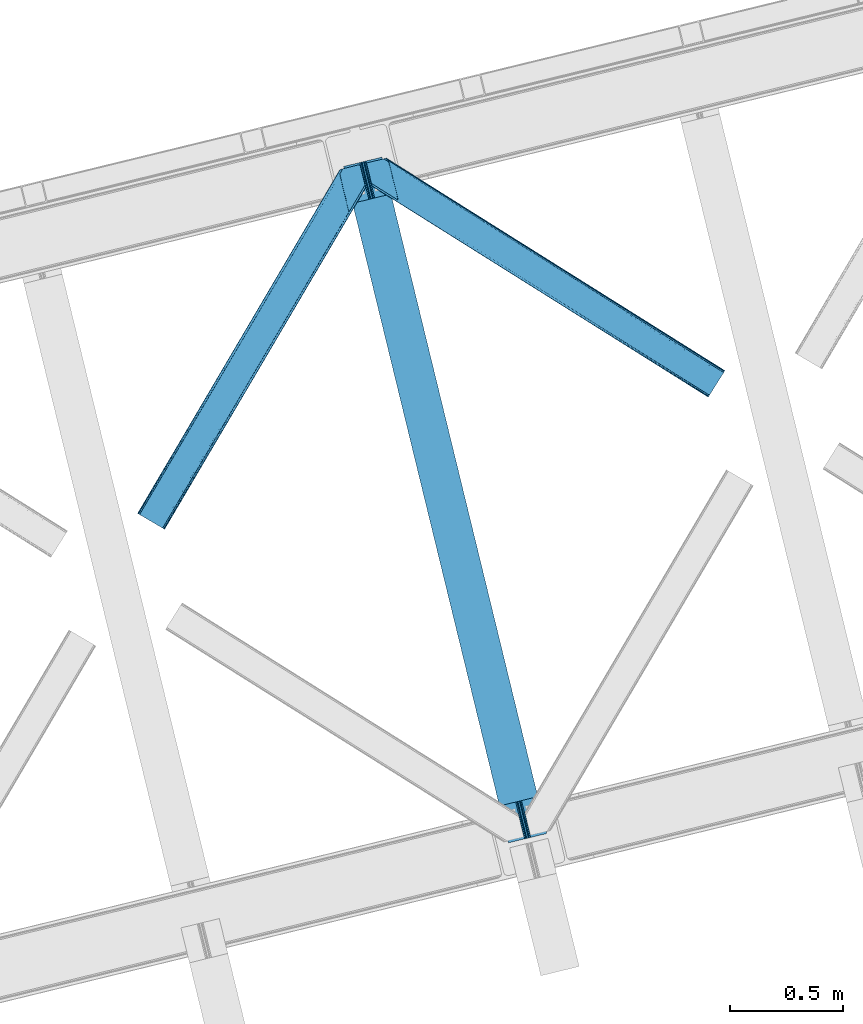
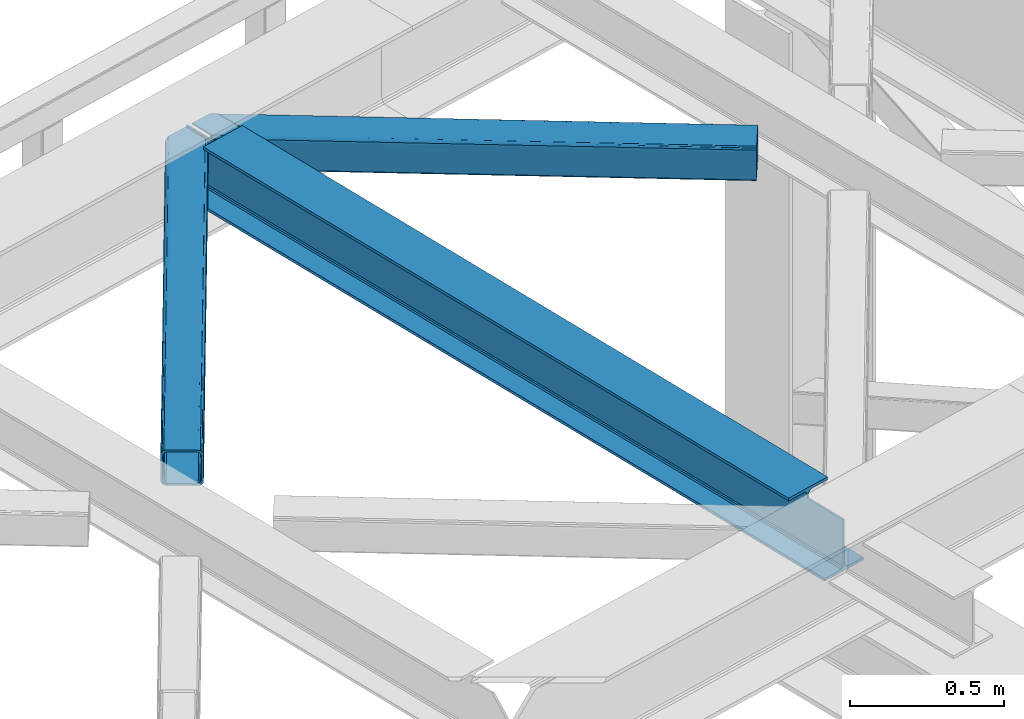
# One storey, part 35 of 93: 2 members, 1 beam.
"""IFC4 building model written with IfcOpenShell, lengths in millimetres."""

import ifcopenshell
import ifcopenshell.guid

model = None  # the IFC model being written
_history = None  # IfcOwnerHistory: only IFC2X3 demands one
_inside = {}  # id of a spatial element -> (the spatial element, [elements in it])
_under = {}  # id of a project, library or spatial element -> (it, [spatial elements below it])
_declared = {}  # id of a project -> (the project, [libraries it declares])
_typed = {}  # id of a type object -> (the type object, [elements of that type])
_made_of = {}  # id of a material, layer set ... -> (it, [elements and type objects made of it])


def new_model(schema):
    """Start an empty IFC model of exactly this schema.

    Asked for "IFC4X3", IfcOpenShell would pick the latest addendum, in which some entities
    have other attributes; the version numbers below select the first issue.
    IFC2X3 requires an IfcOwnerHistory on every rooted entity: one is made here for all.
    """
    global model, _history
    if schema == "IFC4X3":
        model = ifcopenshell.file(schema_version=(4, 3, 0, 0))
    else:
        model = ifcopenshell.file(schema=schema)
    _inside.clear()
    _under.clear()
    _declared.clear()
    _typed.clear()
    _made_of.clear()
    _history = None
    if model.schema == "IFC2X3":
        org = make("IfcOrganization", Name="unknown")
        user = make(
            "IfcPersonAndOrganization",
            ThePerson=make("IfcPerson", FamilyName="unknown"),
            TheOrganization=org,
        )
        app = make(
            "IfcApplication",
            ApplicationDeveloper=org,
            Version="unknown",
            ApplicationFullName="unknown",
            ApplicationIdentifier="unknown",
        )
        _history = make(
            "IfcOwnerHistory",
            OwningUser=user,
            OwningApplication=app,
            ChangeAction="ADDED",
            CreationDate=0,
        )
    return model


def make(cls, **values):
    """One entity of the class cls with the attributes given. An attribute that is None is left unset."""
    return model.create_entity(
        cls, **{name: value for name, value in values.items() if value is not None}
    )


def entity(cls, *values):
    """Any entity or typed value of the class cls, its attributes in the order of the schema. None: left unset."""
    e = model.create_entity(cls)
    for i, value in enumerate(values):
        if value is not None:
            e[i] = value
    return e


def rooted(cls, **values):
    """An entity with a GlobalId (a new one), such as an element, a storey or a relation."""
    return make(cls, GlobalId=ifcopenshell.guid.new(), OwnerHistory=_history, **values)


def si_unit(unit_type, name, prefix=None):
    """IfcSIUnit, for example si_unit("LENGTHUNIT", "METRE", prefix="MILLI")."""
    return make("IfcSIUnit", UnitType=unit_type, Prefix=prefix, Name=name)


def converted_unit(unit_type, name, factor, base, dimensions=None, offset=None):
    """IfcConversionBasedUnit, such as the inch: factor (a typed value) times the base unit."""
    return make(
        "IfcConversionBasedUnit"
        if offset is None
        else "IfcConversionBasedUnitWithOffset",
        ConversionOffset=offset,
        Dimensions=None
        if dimensions is None
        else entity("IfcDimensionalExponents", *dimensions),
        UnitType=unit_type,
        Name=name,
        ConversionFactor=make(
            "IfcMeasureWithUnit", ValueComponent=factor, UnitComponent=base
        ),
    )


def derived_unit(unit_type, elements):
    """IfcDerivedUnit: a product of units, each with its exponent."""
    return make(
        "IfcDerivedUnit",
        Elements=[
            make("IfcDerivedUnitElement", Unit=unit, Exponent=power)
            for unit, power in elements
        ],
        UnitType=unit_type,
    )


def assignment(units):
    """IfcUnitAssignment: the units of a project."""
    return None if units is None else make("IfcUnitAssignment", Units=units)


def point(xyz):
    """IfcCartesianPoint."""
    return None if xyz is None else make("IfcCartesianPoint", Coordinates=xyz)


def direction(xyz):
    """IfcDirection."""
    return None if xyz is None else make("IfcDirection", DirectionRatios=xyz)


def frame(location, z_axis=None, x_axis=None):
    """IfcAxis2Placement3D, a coordinate frame: its origin and axes. An axis left out is left unset."""
    return make(
        "IfcAxis2Placement3D",
        Location=point(location),
        Axis=direction(z_axis),
        RefDirection=direction(x_axis),
    )


def origin():
    """The frame at (0, 0, 0) with its axes left unset."""
    return frame((0.0, 0.0, 0.0))


def place(relative_to, where):
    """IfcLocalPlacement: puts the frame where relative to a parent placement (None: the world)."""
    return make(
        "IfcLocalPlacement", PlacementRelTo=relative_to, RelativePlacement=where
    )


def context(
    kind, dimensions, precision=None, world=None, true_north=None, identifier=None
):
    """IfcGeometricRepresentationContext, for example the 3D "Model" context."""
    return make(
        "IfcGeometricRepresentationContext",
        ContextIdentifier=identifier,
        ContextType=kind,
        CoordinateSpaceDimension=dimensions,
        Precision=precision,
        WorldCoordinateSystem=world,
        TrueNorth=true_north,
    )


def subcontext(parent, identifier, kind, view, scale=None):
    """IfcGeometricRepresentationSubContext, for example "Body" below "Model"."""
    return make(
        "IfcGeometricRepresentationSubContext",
        ContextIdentifier=identifier,
        ContextType=kind,
        ParentContext=parent,
        TargetScale=scale,
        TargetView=view,
    )


def project(units=None, contexts=None):
    """IfcProject with its units and contexts."""
    return rooted(
        "IfcProject",
        Name="project",
        RepresentationContexts=contexts,
        UnitsInContext=assignment(units),
    )


def spatial(cls, under=None, at=None, **own):
    """A site, building, storey or space (cls), placed at a placement, below another one or the project."""
    s = rooted(cls, ObjectPlacement=at, **own)
    if under is not None:
        _under.setdefault(under.id(), (under, []))[1].append(s)
    return s


def point_list(points):
    """IfcCartesianPointList2D or 3D."""
    cls = (
        "IfcCartesianPointList2D" if len(points[0]) == 2 else "IfcCartesianPointList3D"
    )
    return make(cls, CoordList=points)


def triangles(points, corners, closed=None, point_numbers=None):
    """IfcTriangulatedFaceSet: each triangle names its three corners, points numbered from 1."""
    return make(
        "IfcTriangulatedFaceSet",
        Coordinates=point_list(points),
        Closed=closed,
        CoordIndex=corners,
        PnIndex=point_numbers,
    )


def polygons(points, faces, closed=None, point_numbers=None):
    """IfcPolygonalFaceSet: a face is its outer loop, then its inner loops; points numbered from 1."""
    made = []
    for loops in faces:
        if len(loops) == 1:
            made.append(make("IfcIndexedPolygonalFace", CoordIndex=loops[0]))
        else:
            made.append(
                make(
                    "IfcIndexedPolygonalFaceWithVoids",
                    CoordIndex=loops[0],
                    InnerCoordIndices=loops[1:],
                )
            )
    return make(
        "IfcPolygonalFaceSet",
        Coordinates=point_list(points),
        Closed=closed,
        Faces=made,
        PnIndex=point_numbers,
    )


def shape(context_of_items, identifier, shape_type, items):
    """IfcShapeRepresentation: the items that make up one representation, for example the "Body"."""
    return make(
        "IfcShapeRepresentation",
        ContextOfItems=context_of_items,
        RepresentationIdentifier=identifier,
        RepresentationType=shape_type,
        Items=items,
    )


def material(Name=None, Category=None):
    """IfcMaterial."""
    return make("IfcMaterial", Name=Name, Category=Category)


def made_of(thing, what):
    """Note that an element or type object is made of a material, layer set ...; save() writes the relation."""
    if what is not None:
        _made_of.setdefault(what.id(), (what, []))[1].append(thing)
    return thing


def type_object(cls, material=None, **own):
    """A type object (cls), such as IfcWallType, which elements share."""
    return made_of(rooted(cls, **own), material)


def element(
    cls,
    number,
    at=None,
    inside=None,
    cuts=None,
    type_object=None,
    material=None,
    context=None,
    identifier="Body",
    shape_type=None,
    held_by="IfcProductDefinitionShape",
    body=None,
    shapes=None,
    **own,
):
    """One element of the class cls, such as IfcWall. Its Tag is "e" and its number.

    at: its placement. inside: the storey or other place that contains it. cuts: it is an
    opening in that element (IfcRelVoidsElement). A single representation is given by context,
    identifier, shape_type and body (its items); several are given by shapes. held_by: the class
    of the entity that holds the representations. save() writes the other relations.
    """
    e = rooted(cls, Tag="e%d" % number, ObjectPlacement=at, **own)
    if body is not None:
        shapes = [shape(context, identifier, shape_type, body)]
    if shapes is not None:
        e.Representation = make(held_by, Representations=shapes)
    if inside is not None:
        _inside.setdefault(inside.id(), (inside, []))[1].append(e)
    if cuts is not None:
        rooted(
            "IfcRelVoidsElement", RelatingBuildingElement=cuts, RelatedOpeningElement=e
        )
    if type_object is not None:
        _typed.setdefault(type_object.id(), (type_object, []))[1].append(e)
    return made_of(e, material)


def aggregate(whole, parts):
    """IfcRelAggregates: a whole, such as a stair, and the parts it consists of."""
    return rooted("IfcRelAggregates", RelatingObject=whole, RelatedObjects=parts)


def save(model, path):
    """Write the relations noted so far, then the file.

    IfcRelAggregates (storeys below a building ...), IfcRelContainedInSpatialStructure (elements
    in a storey), IfcRelDefinesByType, IfcRelAssociatesMaterial and IfcRelDeclares: one each for
    every whole, place, type object, material and project.
    """
    for whole, parts in _under.values():
        aggregate(whole, parts)
    for where, things in _inside.values():
        rooted(
            "IfcRelContainedInSpatialStructure",
            RelatedElements=things,
            RelatingStructure=where,
        )
    for kind, things in _typed.values():
        rooted("IfcRelDefinesByType", RelatedObjects=things, RelatingType=kind)
    for what, things in _made_of.values():
        rooted("IfcRelAssociatesMaterial", RelatedObjects=things, RelatingMaterial=what)
    for by, libraries in _declared.values():
        rooted("IfcRelDeclares", RelatingContext=by, RelatedDefinitions=libraries)
    model.write(path)


model = new_model("IFC4")

# Units and contexts
model_context = context("Model", 3, precision=0.01, world=origin(), true_north=direction((6.12303176911189e-17, 1.0)))
plan_context = context("Plan", 3, precision=0.01, world=origin(), true_north=direction((6.12303176911189e-17, 1.0)))
body_context = subcontext(model_context, "Body", "Model", "MODEL_VIEW")
ifc_project = project(units=[si_unit("LENGTHUNIT", "METRE", prefix="MILLI"), si_unit("AREAUNIT", "SQUARE_METRE"), si_unit("VOLUMEUNIT", "CUBIC_METRE"), converted_unit("PLANEANGLEUNIT", "DEGREE", entity("IfcRatioMeasure", 0.0174532925199433), si_unit("PLANEANGLEUNIT", "RADIAN"), dimensions=[0, 0, 0, 0, 0, 0, 0]), si_unit("MASSUNIT", "GRAM", prefix="KILO"), derived_unit("MASSDENSITYUNIT", [(si_unit("MASSUNIT", "GRAM", prefix="KILO"), 1), (si_unit("LENGTHUNIT", "METRE"), -3)]), derived_unit("MOMENTOFINERTIAUNIT", [(si_unit("LENGTHUNIT", "METRE"), 4)]), si_unit("TIMEUNIT", "SECOND"), si_unit("FREQUENCYUNIT", "HERTZ"), si_unit("THERMODYNAMICTEMPERATUREUNIT", "DEGREE_CELSIUS"), derived_unit("THERMALTRANSMITTANCEUNIT", [(si_unit("MASSUNIT", "GRAM", prefix="KILO"), 1), (si_unit("THERMODYNAMICTEMPERATUREUNIT", "KELVIN"), -1), (si_unit("TIMEUNIT", "SECOND"), -3)]), derived_unit("VOLUMETRICFLOWRATEUNIT", [(si_unit("LENGTHUNIT", "METRE"), 3), (si_unit("TIMEUNIT", "SECOND"), -1)]), derived_unit("MASSFLOWRATEUNIT", [(si_unit("MASSUNIT", "GRAM", prefix="KILO"), 1), (si_unit("TIMEUNIT", "SECOND"), -1)]), derived_unit("ROTATIONALFREQUENCYUNIT", [(si_unit("TIMEUNIT", "SECOND"), -1)]), si_unit("ELECTRICCURRENTUNIT", "AMPERE"), si_unit("ELECTRICVOLTAGEUNIT", "VOLT"), si_unit("POWERUNIT", "WATT"), si_unit("FORCEUNIT", "NEWTON", prefix="KILO"), si_unit("ILLUMINANCEUNIT", "LUX"), si_unit("LUMINOUSFLUXUNIT", "LUMEN"), si_unit("LUMINOUSINTENSITYUNIT", "CANDELA"), derived_unit("USERDEFINED", [(si_unit("MASSUNIT", "GRAM", prefix="KILO"), -1), (si_unit("LENGTHUNIT", "METRE"), -2), (si_unit("TIMEUNIT", "SECOND"), 3), (si_unit("LUMINOUSFLUXUNIT", "LUMEN"), 1)]), derived_unit("LINEARVELOCITYUNIT", [(si_unit("LENGTHUNIT", "METRE"), 1), (si_unit("TIMEUNIT", "SECOND"), -1)]), si_unit("PRESSUREUNIT", "PASCAL"), derived_unit("USERDEFINED", [(si_unit("LENGTHUNIT", "METRE"), -2), (si_unit("MASSUNIT", "GRAM", prefix="KILO"), 1), (si_unit("TIMEUNIT", "SECOND"), -2)]), derived_unit("LINEARFORCEUNIT", [(si_unit("MASSUNIT", "GRAM", prefix="KILO"), 1), (si_unit("LENGTHUNIT", "METRE"), 1), (si_unit("TIMEUNIT", "SECOND"), -2), (si_unit("LENGTHUNIT", "METRE"), -1)]), derived_unit("PLANARFORCEUNIT", [(si_unit("MASSUNIT", "GRAM", prefix="KILO"), 1), (si_unit("LENGTHUNIT", "METRE"), 1), (si_unit("TIMEUNIT", "SECOND"), -2), (si_unit("LENGTHUNIT", "METRE"), -2)])], contexts=[model_context, plan_context])

# Site, building, storey
site_placement = place(None, origin())
site = spatial("IfcSite", under=ifc_project, at=site_placement, CompositionType="ELEMENT")
building_placement = place(site_placement, origin())
building = spatial("IfcBuilding", under=site, at=building_placement, CompositionType="ELEMENT")
storey_placement = place(building_placement, frame((0.0, 0.0, 15900.0)))
storey = spatial("IfcBuildingStorey", under=building, at=storey_placement, CompositionType="ELEMENT", Elevation=15900.0)

# Beam
ifc_material = material(Name="Metal painted (White)")
beam_type = type_object("IfcBeamType", PredefinedType="BEAM")
beam_placement = place(storey_placement, frame((-52349.2484037346, 5026.02166136888, 3441.0)))
element("IfcBeam", 1, at=beam_placement, inside=storey, type_object=beam_type, material=ifc_material, ObjectType="Steel Beam", PredefinedType="BEAM", context=body_context, shape_type="Tessellation", body=[
    polygons([(900.98534618944, 41.4445662733081, 11.000000000004), (900.98534618944, 41.4445662733092, 2.16573425859679e-12), (170.021610174761, 3040.13999372697, 2.16573425859679e-12), (170.021610174761, 3040.13999372697, 11.000000000004), (834.919806235814, 25.3403919499656, 11.000000000004), (103.956070221144, 3024.03581940362, 11.000000000004), (828.971056214522, 23.8903211957396, 12.2179274798217), (98.0073201998427, 3022.5857486494, 12.2179274798217), (823.927949458413, 22.6610105689194, 15.6862915010192), (92.964213443734, 3021.35643802258, 15.6862915010192), (820.558253255237, 21.8396114687119, 20.8770650821657), (89.5945172405581, 3020.53503892237, 20.8770650821657), (819.374973305552, 21.5511744621195, 27.0000000000047), (88.4112372908723, 3020.24660191578, 27.0000000000047), (81.6103728838888, 3018.58881926485, 27.0000000000047), (81.6103728838801, 3018.58881926485, 203.000000000006), (88.4112372908723, 3020.24660191578, 203.000000000006), (0.0, 2998.69542745366, 2.16573425859679e-12), (0.0, 2998.69542745366, 10.9999999999997), (66.0655399536259, 3014.799601777, 11.000000000004), (72.0142899749184, 3016.24967253123, 12.2179274798217), (77.0573967310183, 3017.47898315805, 15.6862915010192), (80.4270929342029, 3018.30038225826, 20.8770650821657), (819.374973305552, 21.5511744621195, 203.000000000006), (812.574108898559, 19.8933918111876, 203.000000000006), (812.574108898559, 19.8933918111886, 27.0000000000047), (811.390828948873, 19.6049548045974, 20.8770650821657), (808.021132745698, 18.7835557043887, 15.6862915010192), (802.978025989589, 17.5542450775696, 12.2179274798217), (797.029275968305, 16.1041743233425, 11.000000000004), (730.963736014671, 0.0, 10.9999999999997), (730.963736014671, 0.0, 2.16573425859679e-12), (779.675212882749, 184.415062601691, 203.069791966819), (128.020401343504, 2857.75452019162, 203.000000000006), (128.24328213265, 2856.8401777572, 203.617301946336), (128.256196377169, 2856.7871977843, 217.000003693143), (779.530009633824, 185.010597404071, 217.000003676718), (779.530880241722, 185.007025963191, 204.00000679514), (772.964911718311, 182.385463974442, 203.006342981529), (772.742064056773, 183.299815969774, 203.617301946336), (772.729149812254, 183.352795942667, 217.000003693143), (121.455336555608, 2855.1293963229, 217.000003676718), (121.454465947701, 2855.13296776377, 204.00000679514), (121.310166358655, 2855.72494066435, 203.076120467494), (121.219536936511, 2856.09673754069, 203.000000000006), (780.71349435786, 185.298194377514, 223.122939328039), (784.082490766539, 186.122464201393, 228.313710402595), (789.125126170563, 187.353708426697, 231.782072735464), (795.073705041266, 188.80448128138, 232.999999602236), (861.13915590679, 204.909021065315, 232.999999283132), (861.137682570352, 204.915065042187, 243.999994005812), (691.116301666431, 163.469558245298, 243.999994827032), (691.117775002869, 163.463514268423, 233.000000104353), (757.183225868392, 179.568054052358, 232.999999785253), (763.132130996722, 181.017488520583, 231.782072861012), (768.175695503853, 182.244921343717, 228.313710479427), (771.546082413593, 183.063487001147, 223.12293937232), (120.271851831563, 2854.84179934945, 223.122939328039), (116.902855422884, 2854.01752952557, 228.313710402595), (111.860220018877, 2852.78628530027, 231.782072735464), (105.911641148165, 2851.33551244559, 232.999999602236), (39.8461902826419, 2835.23097266165, 232.999999283128), (39.8476636190794, 2835.22492868478, 243.999994005812), (209.869044523001, 2876.67043548167, 243.999994827032), (209.867571186554, 2876.67647945854, 233.000000104357), (143.802120321031, 2860.57193967461, 232.999999785253), (137.853215192701, 2859.12250520639, 231.782072861012), (132.80965068557, 2857.89507238325, 228.313710479427), (129.439263775838, 2857.07650672582, 223.12293937232)], [[[1, 2, 3, 4]], [[5, 1, 4, 6]], [[7, 5, 6, 8]], [[9, 7, 8, 10]], [[11, 9, 10, 12]], [[13, 11, 12, 14]], [[15, 16, 17, 14, 12, 10, 8, 6, 4, 3, 18, 19, 20, 21, 22, 23]], [[13, 24, 25, 26, 27, 28, 29, 30, 31, 32, 2, 1, 5, 7, 9, 11]], [[2, 32, 18, 3]], [[32, 31, 19, 18]], [[31, 30, 20, 19]], [[27, 26, 15, 23]], [[28, 27, 23, 22]], [[29, 28, 22, 21]], [[30, 29, 21, 20]], [[33, 24, 13, 14, 17, 34, 35, 36, 37, 38]], [[25, 39, 40, 41, 42, 43, 44, 16, 15, 26]], [[39, 25, 24, 33]], [[45, 34, 17, 16]], [[41, 40, 38, 37, 46, 47, 48, 49, 50, 51, 52, 53, 54, 55, 56, 57]], [[42, 58, 59, 60, 61, 62, 63, 64, 65, 66, 67, 68, 69, 36, 35, 43]], [[46, 37, 36, 69]], [[47, 46, 69, 68]], [[48, 47, 68, 67]], [[49, 48, 67, 66]], [[50, 49, 66, 65]], [[51, 50, 65, 64]], [[52, 51, 64, 63]], [[53, 52, 63, 62]], [[54, 53, 62, 61]], [[55, 54, 61, 60]], [[56, 55, 60, 59]], [[57, 56, 59, 58]], [[41, 57, 58, 42]]], closed=False),
])

# Members
member_type_1 = type_object("IfcMemberType", PredefinedType="BRACE")
member_1_placement = place(storey_placement, frame((-52247.5317993164, 7001.52786712647, 3511.0000579834)))
element("IfcMember", 2, at=member_1_placement, inside=storey, type_object=member_type_1, ObjectType="Steel Horizontal Brace", PredefinedType="BRACE", context=body_context, shape_type="Tessellation", body=[
    triangles([(207.717553710936, 841.064360046387, 0.0), (172.040661621089, 987.427519226075, 0.0), (1579.91751708985, 103.755294799805, 0.0), (1524.09766845703, 14.8223510742191, 0.0), (1589.22392578125, 118.577645874024, 17.5000946044929), (1588.51234130859, 117.449226379395, 10.8028289794929), (166.547973632813, 1009.96393432617, 10.8028289794929), (166.092187499999, 1011.82079772949, 17.5000946044929), (1586.49851074219, 114.236050415039, 5.12526855468968), (167.836267089842, 1004.67646636963, 5.12526855468968), (1583.48009033203, 109.42762298584, 1.33247680664135), (169.766381835936, 996.762414550782, 1.33247680664135), (1520.53974609375, 9.15002288818323, 1.33247680664135), (202.587634277341, 836.379180908203, 1.33247680664135), (208.508203124999, 837.822697448731, 0.155804443362285), (1517.52132568359, 4.34159545898456, 5.12526855468968), (194.895080566406, 834.504295349121, 5.12526855468968), (1515.50284423828, 1.12841949462927, 10.8028289794929), (189.755859375, 833.250883483887, 10.8028289794929), (1514.79591064453, 0.0, 17.5000946044929), (187.946667480464, 832.811375427246, 17.5000946044929), (204.378222656247, 836.815782165528, 12.1260040283232), (208.508203124999, 837.822697448731, 9.69243164062573), (199.648278808592, 835.662945556641, 17.9802978515654), (198.420446777345, 835.364126586915, 19.4999725341804), (187.946667480464, 832.811375427246, 19.4999725341804), (25.3054321289019, 934.895260620117, 19.4999725341804), (22.6823364257798, 945.669602966309, 19.4999725341804), (1514.79591064453, 0.0, 122.500662231447), (25.3054321289019, 934.895260620117, 122.500662231447), (1527.81837158203, 20.7510589599606, 6.99957275390625), (205.340954589839, 850.821903991699, 6.99957275390625), (207.559423828126, 841.724784851074, 8.88434143066479), (1524.26044921875, 15.0787307739256, 8.3320495605476), (1521.24202880859, 10.2703033447269, 12.1260040283232), (1519.22354736328, 7.05712738037073, 17.8035644531265), (1518.51661376953, 5.92870788574237, 24.4996673583992), (22.9288330078125, 944.65280456543, 24.4996673583992), (174.417260742186, 977.669975280762, 6.99957275390625), (1576.19681396485, 97.8265869140623, 6.99957275390625), (168.966430664063, 1000.03372650147, 17.8803039550803), (170.212866210939, 994.918922424316, 12.1260040283232), (172.142980957033, 987.004870605469, 8.3320495605476), (168.831555175777, 1000.58485565186, 18.5000335693367), (166.092187499999, 1011.82079772949, 18.5000335693367), (1518.51661376953, 5.92870788574237, 115.501089477541), (22.9288330078125, 944.65280456543, 115.501089477541), (1527.81837158203, 20.7510589599606, 133.000021362306), (1524.26044921875, 15.0787307739256, 131.667544555665), (19.2592895507769, 959.711187744141, 131.667544555665), (16.9803588867144, 969.046664428711, 133.000021362306), (1521.24202880859, 10.2703033447269, 127.87475280762), (21.1847534179688, 951.797135925293, 127.87475280762), (1519.22354736328, 7.05712738037073, 122.196029663086), (22.4776977539077, 946.50966796875, 122.196029663086), (168.515295410158, 1000.87902374268, 18.7407165527366), (165.808483886714, 1012.00160064697, 18.736065673831), (168.171130371091, 1001.19702758789, 19.0000030517585), (165.487573242186, 1012.20275115967, 19.0000030517585), (167.822314453122, 1001.51503143311, 19.2592895507842), (165.166662597658, 1012.4033203125, 19.2639404296897), (167.506054687496, 1001.80919952393, 19.4999725341804), (164.878308105464, 1012.58412322998, 19.4999725341804), (78.2928955078096, 1057.80520019531, 19.4999725341804), (88.7666748046831, 1060.35795135498, 19.4999725341804), (24.8542968749971, 936.752124023437, 129.197927856447), (23.5660034179673, 942.040173339844, 134.874325561526), (22.1195800781206, 947.964811706544, 137.999716186525), (0.0, 1038.71973724365, 137.999716186525), (0.0, 1038.71973724365, 133.000021362306), (1589.22392578125, 118.577645874024, 122.500662231447), (88.7666748046831, 1060.35795135498, 122.500662231447), (1584.79163818359, 111.520518493652, 17.8035644531265), (1585.49857177735, 112.648356628418, 24.4996673583992), (79.2788818359331, 1058.04588317871, 24.4996673583992), (1579.75938720703, 103.498915100097, 8.3320495605476), (1582.77780761719, 108.307342529297, 12.1260040283232), (64.6425659179658, 1054.47807769775, 131.667544555665), (55.5687011718765, 1052.26600341797, 133.000021362306), (76.0604736328096, 1057.26104736328, 137.999716186525), (81.8182617187485, 1058.66503143311, 134.874325561526), (72.3351196289077, 1056.35296325684, 127.87475280762), (77.474340820314, 1057.60579376221, 122.196029663086), (86.962133789064, 1059.91786193848, 129.197927856447), (79.2788818359331, 1058.04588317871, 115.501089477541), (1576.19681396485, 97.8265869140623, 133.000021362306), (1585.49857177735, 112.648356628418, 115.501089477541), (1584.79163818359, 111.520518493652, 122.196029663086), (1582.77780761719, 108.307342529297, 127.87475280762), (1579.75938720703, 103.498915100097, 131.667544555665), (1588.51234130859, 117.449226379395, 129.197927856447), (1586.49851074219, 114.236050415039, 134.874325561526), (1583.48009033203, 109.42762298584, 138.667117309571), (1579.91751708985, 103.755294799805, 139.999594116212), (1524.09766845703, 14.8223510742191, 139.999594116212), (1520.53974609375, 9.15002288818323, 138.667117309571), (1517.52132568359, 4.34159545898456, 134.874325561526), (1515.50284423828, 1.12841949462927, 129.197927856447), (98.1893554687485, 1043.37177886963, 137.999716186525), (139.386840820313, 874.360583496094, 137.999716186525), (137.842749023439, 884.922148132325, 139.999594116212), (139.824023437497, 876.794155883789, 138.999655151369), (140.051916503908, 875.6302734375, 138.667117309571), (139.805419921875, 874.273379516601, 138.076455688479), (139.917041015622, 874.907643127442, 138.353182983399), (98.7056030273452, 1042.87529754639, 138.076455688479), (99.5985717773438, 1040.78589019775, 138.634561157229), (99.1985961914033, 1041.72362365723, 138.383413696291), (100.184582519527, 1039.41271820068, 138.999655151369), (102.165856933592, 1031.28472595215, 139.999594116212), (140.033312988278, 875.544232177735, 138.629910278323)], [[1, 2, 3], [3, 4, 1], [5, 6, 7], [7, 8, 5], [6, 9, 10], [10, 7, 6], [9, 11, 12], [12, 10, 9], [11, 3, 2], [2, 12, 11], [13, 14, 15], [15, 4, 13], [15, 1, 4], [13, 16, 14], [17, 14, 16], [16, 18, 17], [19, 17, 18], [18, 20, 19], [21, 19, 20], [22, 23, 14], [22, 14, 17], [17, 19, 24], [23, 15, 14], [24, 22, 17], [19, 21, 25], [26, 25, 21], [19, 25, 24], [27, 28, 25], [25, 26, 27], [26, 29, 30], [20, 26, 21], [26, 20, 29], [26, 30, 27], [31, 32, 33], [34, 33, 23], [23, 35, 34], [23, 22, 35], [36, 35, 22], [37, 36, 24], [24, 25, 37], [37, 25, 38], [28, 38, 25], [22, 24, 36], [33, 34, 31], [39, 32, 40], [31, 40, 32], [41, 7, 10], [10, 42, 41], [12, 42, 10], [42, 12, 43], [7, 44, 8], [45, 8, 44], [7, 41, 44], [43, 12, 2], [33, 32, 1], [1, 39, 2], [39, 1, 32], [15, 33, 1], [39, 43, 2], [23, 33, 15], [46, 37, 38], [38, 47, 46], [48, 49, 50], [50, 51, 48], [49, 52, 53], [53, 50, 49], [52, 54, 55], [55, 53, 52], [54, 46, 47], [47, 55, 54], [45, 44, 56], [56, 57, 45], [57, 56, 58], [58, 59, 57], [59, 58, 60], [60, 61, 59], [61, 60, 62], [62, 63, 61], [64, 65, 63], [63, 62, 64], [47, 27, 30], [66, 55, 30], [55, 66, 67], [55, 47, 30], [38, 27, 47], [28, 27, 38], [53, 55, 67], [68, 51, 50], [51, 68, 69], [69, 70, 51], [50, 53, 68], [68, 53, 67], [5, 45, 71], [8, 45, 5], [45, 72, 71], [72, 45, 57], [72, 57, 59], [59, 61, 72], [63, 72, 61], [72, 63, 65], [73, 41, 42], [74, 75, 62], [62, 73, 74], [56, 73, 58], [56, 44, 73], [73, 60, 58], [73, 62, 60], [44, 41, 73], [75, 64, 62], [40, 76, 39], [43, 39, 76], [76, 77, 43], [42, 43, 77], [42, 77, 73], [78, 79, 80], [81, 82, 80], [78, 80, 82], [83, 81, 84], [79, 69, 80], [79, 70, 69], [83, 82, 81], [72, 85, 83], [85, 72, 65], [75, 65, 64], [65, 75, 85], [72, 83, 84], [51, 79, 86], [79, 51, 70], [86, 48, 51], [74, 87, 85], [85, 75, 74], [87, 88, 85], [83, 85, 88], [88, 89, 83], [82, 83, 89], [89, 90, 82], [78, 82, 90], [90, 86, 78], [79, 78, 86], [91, 89, 88], [87, 5, 71], [91, 88, 71], [91, 92, 89], [88, 87, 71], [89, 92, 93], [86, 94, 95], [94, 90, 93], [90, 94, 86], [90, 89, 93], [6, 77, 9], [74, 5, 87], [5, 73, 6], [73, 5, 74], [6, 73, 77], [3, 40, 4], [11, 9, 77], [77, 76, 11], [76, 40, 3], [3, 11, 76], [52, 96, 97], [95, 48, 86], [95, 49, 48], [49, 95, 96], [52, 49, 96], [46, 29, 20], [98, 54, 52], [97, 98, 52], [54, 98, 29], [46, 54, 29], [13, 35, 16], [4, 40, 31], [31, 34, 4], [34, 35, 13], [13, 4, 34], [18, 16, 35], [20, 37, 46], [36, 20, 18], [20, 36, 37], [36, 18, 35], [80, 68, 99], [80, 69, 68], [100, 99, 68], [95, 101, 102], [102, 96, 95], [102, 103, 96], [97, 104, 100], [100, 67, 97], [100, 68, 67], [96, 105, 104], [96, 103, 105], [104, 97, 96], [29, 98, 30], [66, 30, 98], [98, 97, 66], [67, 66, 97], [92, 81, 106], [106, 93, 92], [107, 93, 108], [106, 108, 93], [81, 80, 99], [107, 94, 93], [107, 109, 94], [109, 110, 94], [92, 91, 84], [84, 81, 92], [91, 71, 72], [72, 84, 91], [110, 101, 94], [95, 94, 101], [111, 102, 109], [109, 107, 111], [107, 108, 104], [108, 106, 104], [110, 109, 101], [102, 101, 109]]),
])
member_type_2 = type_object("IfcMemberType", PredefinedType="BRACE")
member_2_placement = place(storey_placement, frame((-53262.9302856445, 6415.9455871582, 3511.0000579834)))
element("IfcMember", 3, at=member_2_placement, inside=storey, type_object=member_type_2, ObjectType="Steel Horizontal Brace", PredefinedType="BRACE", context=body_context, shape_type="Tessellation", body=[
    triangles([(105.565649414064, 8.87852783203107, 0.0), (15.0781494140683, 62.148532104492, 0.0), (892.847827148442, 1346.13992614746, 0.0), (857.166284179693, 1492.50250396729, 0.0), (854.892004394533, 1501.83739929199, 1.33247680664135), (9.31105957031832, 65.5459991455082, 1.33247680664135), (852.961889648439, 1509.75145111084, 5.12526855468968), (4.4183349609375, 68.4266372680668, 5.12526855468968), (851.673596191409, 1515.03950042725, 10.8028289794929), (1.14876708984957, 70.3509384155277, 10.8028289794929), (851.222460937504, 1516.89636383057, 17.5000946044929), (0.0, 71.027059936524, 17.5000946044929), (893.633825683595, 1342.89826354981, 0.155804443362285), (111.332739257814, 5.48106079101581, 1.33247680664135), (899.559045410162, 1344.34178009033, 1.33247680664135), (912.390820312503, 1347.46949615479, 10.8028289794929), (914.195361328129, 1347.90958557129, 17.5000946044929), (120.643798828125, 0.0, 17.5000946044929), (119.495031738283, 0.675540161132631, 10.8028289794929), (907.251599121097, 1346.21666564941, 5.12526855468968), (116.225463867188, 2.60042266845721, 5.12526855468968), (902.493750000001, 1345.05743408203, 17.9802978515654), (893.633825683595, 1342.89826354981, 9.69243164062573), (897.768457031256, 1343.90459747315, 12.1260040283232), (903.721582031256, 1345.35683441162, 19.4999725341804), (914.195361328129, 1347.90958557129, 19.4999725341804), (1011.61732177735, 1513.38669433594, 19.4999725341804), (1008.98957519532, 1524.16103668213, 19.4999725341804), (1011.61732177735, 1513.38669433594, 122.500662231447), (120.643798828125, 0.0, 122.500662231447), (114.61160888672, 3.5515274047857, 24.4996673583992), (1009.23607177735, 1523.14423828125, 24.4996673583992), (113.462841796878, 4.22706756591833, 17.8035644531265), (110.193273925783, 6.15195007324201, 12.1260040283232), (105.300549316409, 9.03200683593786, 8.3320495605476), (99.52880859375, 12.4294738769531, 6.99957275390625), (892.685046386723, 1346.79976959229, 8.88434143066479), (890.466577148443, 1355.89747009277, 6.99957275390625), (21.1103393554731, 58.5975860595709, 6.99957275390625), (859.547534179692, 1482.74496002197, 6.99957275390625), (853.961828613283, 1505.66042175293, 18.5000335693367), (851.222460937504, 1516.89636383057, 18.5000335693367), (854.096704101568, 1505.10929260254, 17.8803039550803), (855.343139648438, 1499.99390716553, 12.1260040283232), (857.273254394531, 1492.07985534668, 8.3320495605476), (1009.23607177735, 1523.14423828125, 115.501089477541), (114.61160888672, 3.5515274047857, 115.501089477541), (1008.78493652344, 1525.00110168457, 122.196029663086), (113.462841796878, 4.22706756591833, 122.196029663086), (1007.49664306641, 1530.28915100098, 127.87475280762), (110.193273925783, 6.15195007324201, 127.87475280762), (1005.56652832031, 1538.20320281982, 131.667544555665), (105.300549316409, 9.03200683593786, 131.667544555665), (1003.29224853516, 1547.53809814453, 133.000021362306), (99.52880859375, 12.4294738769531, 133.000021362306), (851.952648925784, 1518.13291625977, 19.4999725341804), (854.575744628906, 1507.35857391357, 19.4999725341804), (851.780566406254, 1517.84049224854, 19.2639404296897), (854.426916503908, 1506.95045928955, 19.2592895507842), (851.585229492193, 1517.51434936523, 19.0000030517585), (854.268786621098, 1506.50920715332, 19.0000030517585), (851.394543457034, 1517.1887878418, 18.736065673831), (854.110656738281, 1506.06853637695, 18.7407165527366), (908.014343261719, 1598.12687072754, 19.4999725341804), (897.540563964845, 1595.57411956787, 19.4999725341804), (1011.16618652344, 1515.24355773926, 129.197927856447), (1009.8732421875, 1520.53160705566, 134.874325561526), (1008.43146972657, 1526.45624542236, 137.999716186525), (986.307238769536, 1617.21175231934, 137.999716186525), (986.307238769536, 1617.21175231934, 133.000021362306), (897.540563964845, 1595.57411956787, 122.500662231447), (0.0, 71.027059936524, 122.500662231447), (7.18095703125437, 66.7999923706057, 17.8035644531265), (10.4505249023496, 64.8751098632811, 12.1260040283232), (6.03218994141207, 67.4755325317383, 24.4996673583992), (907.023706054693, 1597.88560638428, 24.4996673583992), (15.3432495117231, 61.9944717407225, 8.3320495605476), (908.832897949222, 1598.32569580078, 122.196029663086), (899.345104980472, 1596.01362762451, 129.197927856447), (904.484326171878, 1597.26645812988, 134.874325561526), (930.73388671875, 1603.66548614502, 133.000021362306), (910.246765136719, 1598.67044219971, 137.999716186525), (921.664672851563, 1601.45341186523, 131.667544555665), (913.972119140628, 1599.57852630615, 127.87475280762), (907.023706054693, 1597.88560638428, 115.501089477541), (21.1103393554731, 58.5975860595709, 133.000021362306), (6.03218994141207, 67.4755325317383, 115.501089477541), (15.3432495117231, 61.9944717407225, 131.667544555665), (10.4505249023496, 64.8751098632811, 127.87475280762), (7.18095703125437, 66.7999923706057, 122.196029663086), (119.495031738283, 0.675540161132631, 129.197927856447), (116.225463867188, 2.60042266845721, 134.874325561526), (111.332739257814, 5.48106079101581, 138.667117309571), (105.565649414064, 8.87852783203107, 139.999594116212), (15.0781494140683, 62.148532104492, 139.999594116212), (9.31105957031832, 65.5459991455082, 138.667117309571), (4.4183349609375, 68.4266372680668, 134.874325561526), (1.14876708984957, 70.3509384155277, 129.197927856447), (896.991760253906, 1576.15611877441, 137.999716186525), (938.18924560547, 1407.14434204102, 137.999716186525), (899.024194335943, 1563.59525756836, 139.999594116212), (897.042919921878, 1571.72266845703, 138.999655151369), (896.796423339845, 1573.13711700439, 138.639212036134), (896.926647949222, 1575.15443572998, 138.211331176761), (896.861535644537, 1574.14170684815, 138.427597045898), (937.473010253911, 1407.08562469482, 138.29272155762), (937.077685546879, 1408.09486541748, 138.646188354494), (936.682360839848, 1409.10410614014, 138.999655151369), (934.701086425783, 1417.23267974854, 139.999594116212)], [[1, 2, 3], [4, 3, 2], [5, 4, 6], [2, 6, 4], [7, 5, 8], [6, 8, 5], [9, 7, 10], [8, 10, 7], [11, 9, 12], [10, 12, 9], [1, 3, 13], [13, 14, 1], [13, 15, 14], [16, 17, 18], [18, 19, 16], [20, 16, 19], [19, 21, 20], [15, 20, 21], [21, 14, 15], [20, 22, 16], [23, 24, 15], [23, 15, 13], [15, 24, 20], [16, 25, 17], [20, 24, 22], [16, 22, 25], [26, 17, 25], [26, 25, 27], [28, 27, 25], [27, 29, 26], [30, 26, 29], [26, 18, 17], [30, 18, 26], [31, 32, 25], [25, 33, 31], [25, 22, 33], [32, 28, 25], [33, 22, 24], [34, 24, 23], [23, 35, 34], [36, 35, 37], [37, 38, 36], [23, 37, 35], [24, 34, 33], [39, 36, 38], [38, 40, 39], [9, 11, 41], [11, 42, 41], [43, 9, 41], [43, 7, 9], [44, 7, 43], [5, 44, 45], [44, 5, 7], [4, 5, 45], [45, 40, 4], [37, 23, 13], [37, 3, 38], [3, 40, 38], [40, 3, 4], [37, 13, 3], [46, 32, 31], [31, 47, 46], [48, 46, 49], [47, 49, 46], [50, 48, 51], [49, 51, 48], [52, 50, 53], [51, 53, 50], [54, 52, 55], [53, 55, 52], [56, 57, 58], [59, 58, 57], [58, 59, 60], [61, 60, 59], [60, 61, 62], [63, 62, 61], [62, 63, 42], [41, 42, 63], [57, 56, 64], [65, 64, 56], [66, 48, 67], [46, 29, 27], [27, 32, 46], [32, 27, 28], [48, 29, 46], [66, 29, 48], [50, 68, 67], [52, 68, 50], [67, 48, 50], [52, 54, 68], [54, 69, 68], [70, 69, 54], [71, 60, 62], [58, 60, 71], [71, 56, 58], [56, 71, 65], [42, 12, 72], [12, 42, 11], [71, 42, 72], [42, 71, 62], [73, 74, 44], [75, 73, 43], [43, 41, 75], [43, 57, 75], [64, 76, 57], [75, 57, 76], [44, 43, 73], [45, 44, 74], [74, 77, 45], [40, 45, 77], [77, 39, 40], [78, 79, 80], [81, 82, 69], [69, 70, 81], [81, 83, 82], [84, 82, 83], [80, 82, 84], [78, 71, 79], [85, 71, 78], [80, 84, 78], [65, 76, 64], [85, 65, 71], [76, 65, 85], [86, 54, 55], [54, 86, 81], [70, 54, 81], [76, 85, 87], [87, 75, 76], [83, 81, 86], [86, 88, 83], [84, 83, 88], [88, 89, 84], [78, 84, 89], [89, 90, 78], [85, 78, 90], [90, 87, 85], [91, 51, 49], [47, 18, 30], [91, 49, 30], [91, 92, 51], [49, 47, 30], [51, 92, 93], [55, 94, 95], [94, 53, 93], [53, 94, 55], [53, 51, 93], [19, 34, 21], [31, 18, 47], [18, 33, 19], [33, 18, 31], [19, 33, 34], [1, 36, 2], [14, 21, 34], [34, 35, 14], [35, 36, 1], [1, 14, 35], [89, 96, 97], [95, 86, 55], [95, 88, 86], [88, 95, 96], [89, 88, 96], [87, 72, 12], [98, 90, 89], [97, 98, 89], [90, 98, 72], [87, 90, 72], [6, 74, 8], [2, 36, 39], [39, 77, 2], [77, 74, 6], [6, 2, 77], [10, 8, 74], [12, 75, 87], [73, 12, 10], [12, 73, 75], [73, 10, 74], [99, 68, 82], [99, 100, 68], [68, 69, 82], [96, 95, 101], [101, 102, 96], [97, 96, 103], [104, 97, 105], [104, 99, 97], [97, 103, 105], [82, 80, 99], [97, 99, 80], [102, 103, 96], [79, 71, 98], [72, 98, 71], [80, 79, 97], [98, 97, 79], [92, 67, 100], [100, 93, 92], [67, 68, 100], [106, 107, 93], [94, 93, 107], [107, 108, 94], [108, 109, 94], [66, 67, 92], [92, 91, 66], [29, 66, 91], [91, 30, 29], [95, 94, 109], [109, 101, 95], [107, 103, 102], [105, 103, 107], [106, 104, 105], [100, 99, 104], [107, 106, 105], [102, 108, 107], [102, 101, 109], [109, 108, 102]]),
])

save(model, "model.ifc")
